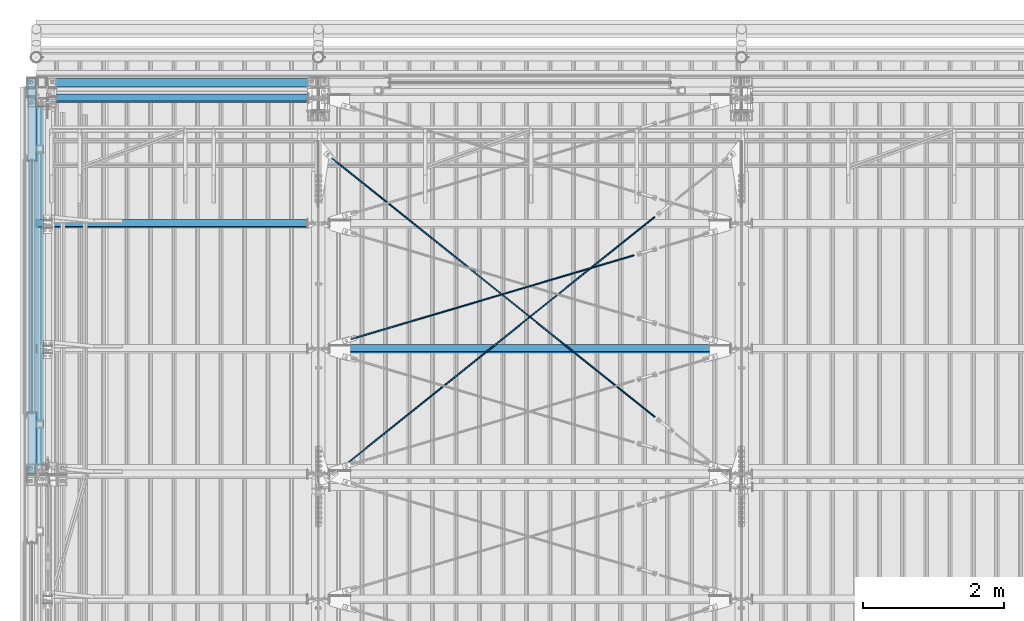
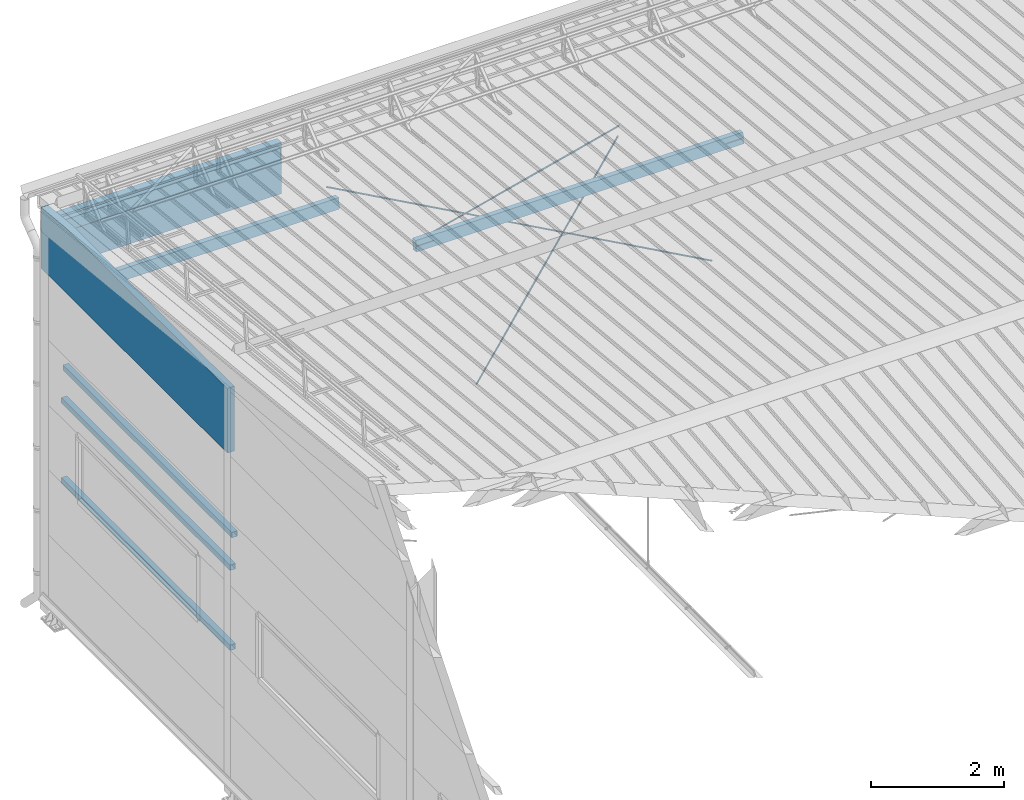
# One storey, part 264 of 709: 11 beams, 5 openings, 11 elements without a shape of their own.
"""IFC4 building model written with IfcOpenShell, lengths in millimetres."""

import ifcopenshell
import ifcopenshell.guid

model = None  # the IFC model being written
_history = None  # IfcOwnerHistory: only IFC2X3 demands one
_inside = {}  # id of a spatial element -> (the spatial element, [elements in it])
_under = {}  # id of a project, library or spatial element -> (it, [spatial elements below it])
_declared = {}  # id of a project -> (the project, [libraries it declares])
_typed = {}  # id of a type object -> (the type object, [elements of that type])
_made_of = {}  # id of a material, layer set ... -> (it, [elements and type objects made of it])


def new_model(schema):
    """Start an empty IFC model of exactly this schema.

    Asked for "IFC4X3", IfcOpenShell would pick the latest addendum, in which some entities
    have other attributes; the version numbers below select the first issue.
    IFC2X3 requires an IfcOwnerHistory on every rooted entity: one is made here for all.
    """
    global model, _history
    if schema == "IFC4X3":
        model = ifcopenshell.file(schema_version=(4, 3, 0, 0))
    else:
        model = ifcopenshell.file(schema=schema)
    _inside.clear()
    _under.clear()
    _declared.clear()
    _typed.clear()
    _made_of.clear()
    _history = None
    if model.schema == "IFC2X3":
        org = make("IfcOrganization", Name="unknown")
        user = make(
            "IfcPersonAndOrganization",
            ThePerson=make("IfcPerson", FamilyName="unknown"),
            TheOrganization=org,
        )
        app = make(
            "IfcApplication",
            ApplicationDeveloper=org,
            Version="unknown",
            ApplicationFullName="unknown",
            ApplicationIdentifier="unknown",
        )
        _history = make(
            "IfcOwnerHistory",
            OwningUser=user,
            OwningApplication=app,
            ChangeAction="ADDED",
            CreationDate=0,
        )
    return model


def make(cls, **values):
    """One entity of the class cls with the attributes given. An attribute that is None is left unset."""
    return model.create_entity(
        cls, **{name: value for name, value in values.items() if value is not None}
    )


def rooted(cls, **values):
    """An entity with a GlobalId (a new one), such as an element, a storey or a relation."""
    return make(cls, GlobalId=ifcopenshell.guid.new(), OwnerHistory=_history, **values)


def si_unit(unit_type, name, prefix=None):
    """IfcSIUnit, for example si_unit("LENGTHUNIT", "METRE", prefix="MILLI")."""
    return make("IfcSIUnit", UnitType=unit_type, Prefix=prefix, Name=name)


def assignment(units):
    """IfcUnitAssignment: the units of a project."""
    return None if units is None else make("IfcUnitAssignment", Units=units)


def point(xyz):
    """IfcCartesianPoint."""
    return None if xyz is None else make("IfcCartesianPoint", Coordinates=xyz)


def direction(xyz):
    """IfcDirection."""
    return None if xyz is None else make("IfcDirection", DirectionRatios=xyz)


def frame(location, z_axis=None, x_axis=None):
    """IfcAxis2Placement3D, a coordinate frame: its origin and axes. An axis left out is left unset."""
    return make(
        "IfcAxis2Placement3D",
        Location=point(location),
        Axis=direction(z_axis),
        RefDirection=direction(x_axis),
    )


def origin_with_axes():
    """The frame at (0, 0, 0) with the z axis (0, 0, 1) and the x axis (1, 0, 0) written out."""
    return frame((0.0, 0.0, 0.0), z_axis=(0.0, 0.0, 1.0), x_axis=(1.0, 0.0, 0.0))


def place(relative_to, where):
    """IfcLocalPlacement: puts the frame where relative to a parent placement (None: the world)."""
    return make(
        "IfcLocalPlacement", PlacementRelTo=relative_to, RelativePlacement=where
    )


def context(
    kind, dimensions, precision=None, world=None, true_north=None, identifier=None
):
    """IfcGeometricRepresentationContext, for example the 3D "Model" context."""
    return make(
        "IfcGeometricRepresentationContext",
        ContextIdentifier=identifier,
        ContextType=kind,
        CoordinateSpaceDimension=dimensions,
        Precision=precision,
        WorldCoordinateSystem=world,
        TrueNorth=true_north,
    )


def subcontext(parent, identifier, kind, view, scale=None):
    """IfcGeometricRepresentationSubContext, for example "Body" below "Model"."""
    return make(
        "IfcGeometricRepresentationSubContext",
        ContextIdentifier=identifier,
        ContextType=kind,
        ParentContext=parent,
        TargetScale=scale,
        TargetView=view,
    )


def project(units=None, contexts=None):
    """IfcProject with its units and contexts."""
    return rooted(
        "IfcProject",
        Name="project",
        RepresentationContexts=contexts,
        UnitsInContext=assignment(units),
    )


def spatial(cls, under=None, at=None, **own):
    """A site, building, storey or space (cls), placed at a placement, below another one or the project."""
    s = rooted(cls, ObjectPlacement=at, **own)
    if under is not None:
        _under.setdefault(under.id(), (under, []))[1].append(s)
    return s


def point_list(points):
    """IfcCartesianPointList2D or 3D."""
    cls = (
        "IfcCartesianPointList2D" if len(points[0]) == 2 else "IfcCartesianPointList3D"
    )
    return make(cls, CoordList=points)


def line(*indices):
    """IfcLineIndex: a straight run through numbered points of an indexed curve."""
    return model.create_entity("IfcLineIndex", indices)


def indexed_curve(points, segments=None, self_intersect=None):
    """IfcIndexedPolyCurve: lines and arcs through numbered points (the first is 1)."""
    return make(
        "IfcIndexedPolyCurve",
        Points=point_list(points),
        Segments=segments,
        SelfIntersect=self_intersect,
    )


def outline(outer, holes=None, kind="AREA"):
    """IfcArbitraryClosedProfileDef: a profile drawn as a closed curve; with holes, ...WithVoids."""
    if holes is None:
        return make("IfcArbitraryClosedProfileDef", ProfileType=kind, OuterCurve=outer)
    return make(
        "IfcArbitraryProfileDefWithVoids",
        ProfileType=kind,
        OuterCurve=outer,
        InnerCurves=holes,
    )


def extrude(swept, where, along, depth):
    """IfcExtrudedAreaSolid: the profile swept, set in the frame where, extruded along a direction by depth."""
    return make(
        "IfcExtrudedAreaSolid",
        SweptArea=swept,
        Position=where,
        ExtrudedDirection=direction(along),
        Depth=depth,
    )


def polygons(points, faces, closed=None, point_numbers=None):
    """IfcPolygonalFaceSet: a face is its outer loop, then its inner loops; points numbered from 1."""
    made = []
    for loops in faces:
        if len(loops) == 1:
            made.append(make("IfcIndexedPolygonalFace", CoordIndex=loops[0]))
        else:
            made.append(
                make(
                    "IfcIndexedPolygonalFaceWithVoids",
                    CoordIndex=loops[0],
                    InnerCoordIndices=loops[1:],
                )
            )
    return make(
        "IfcPolygonalFaceSet",
        Coordinates=point_list(points),
        Closed=closed,
        Faces=made,
        PnIndex=point_numbers,
    )


def shape(context_of_items, identifier, shape_type, items):
    """IfcShapeRepresentation: the items that make up one representation, for example the "Body"."""
    return make(
        "IfcShapeRepresentation",
        ContextOfItems=context_of_items,
        RepresentationIdentifier=identifier,
        RepresentationType=shape_type,
        Items=items,
    )


def material(Name=None, Category=None):
    """IfcMaterial."""
    return make("IfcMaterial", Name=Name, Category=Category)


def made_of(thing, what):
    """Note that an element or type object is made of a material, layer set ...; save() writes the relation."""
    if what is not None:
        _made_of.setdefault(what.id(), (what, []))[1].append(thing)
    return thing


def element(
    cls,
    number,
    at=None,
    inside=None,
    cuts=None,
    type_object=None,
    material=None,
    context=None,
    identifier="Body",
    shape_type=None,
    held_by="IfcProductDefinitionShape",
    body=None,
    shapes=None,
    **own,
):
    """One element of the class cls, such as IfcWall. Its Tag is "e" and its number.

    at: its placement. inside: the storey or other place that contains it. cuts: it is an
    opening in that element (IfcRelVoidsElement). A single representation is given by context,
    identifier, shape_type and body (its items); several are given by shapes. held_by: the class
    of the entity that holds the representations. save() writes the other relations.
    """
    e = rooted(cls, Tag="e%d" % number, ObjectPlacement=at, **own)
    if body is not None:
        shapes = [shape(context, identifier, shape_type, body)]
    if shapes is not None:
        e.Representation = make(held_by, Representations=shapes)
    if inside is not None:
        _inside.setdefault(inside.id(), (inside, []))[1].append(e)
    if cuts is not None:
        rooted(
            "IfcRelVoidsElement", RelatingBuildingElement=cuts, RelatedOpeningElement=e
        )
    if type_object is not None:
        _typed.setdefault(type_object.id(), (type_object, []))[1].append(e)
    return made_of(e, material)


def aggregate(whole, parts):
    """IfcRelAggregates: a whole, such as a stair, and the parts it consists of."""
    return rooted("IfcRelAggregates", RelatingObject=whole, RelatedObjects=parts)


def save(model, path):
    """Write the relations noted so far, then the file.

    IfcRelAggregates (storeys below a building ...), IfcRelContainedInSpatialStructure (elements
    in a storey), IfcRelDefinesByType, IfcRelAssociatesMaterial and IfcRelDeclares: one each for
    every whole, place, type object, material and project.
    """
    for whole, parts in _under.values():
        aggregate(whole, parts)
    for where, things in _inside.values():
        rooted(
            "IfcRelContainedInSpatialStructure",
            RelatedElements=things,
            RelatingStructure=where,
        )
    for kind, things in _typed.values():
        rooted("IfcRelDefinesByType", RelatedObjects=things, RelatingType=kind)
    for what, things in _made_of.values():
        rooted("IfcRelAssociatesMaterial", RelatedObjects=things, RelatingMaterial=what)
    for by, libraries in _declared.values():
        rooted("IfcRelDeclares", RelatingContext=by, RelatedDefinitions=libraries)
    model.write(path)


model = new_model("IFC4")

# Units and contexts
model_context = context("Model", 3, precision=0.2, world=origin_with_axes(), true_north=direction((0.0, 1.0)))
body_context = subcontext(model_context, "Body", "Model", "MODEL_VIEW")
reference_context = subcontext(model_context, "Reference", "Model", "MODEL_VIEW")
ifc_project = project(units=[si_unit("LENGTHUNIT", "METRE", prefix="MILLI"), si_unit("AREAUNIT", "SQUARE_METRE"), si_unit("VOLUMEUNIT", "CUBIC_METRE"), si_unit("MASSUNIT", "GRAM", prefix="KILO"), si_unit("TIMEUNIT", "SECOND"), si_unit("PLANEANGLEUNIT", "RADIAN"), si_unit("SOLIDANGLEUNIT", "STERADIAN"), si_unit("THERMODYNAMICTEMPERATUREUNIT", "DEGREE_CELSIUS"), si_unit("LUMINOUSINTENSITYUNIT", "LUMEN")], contexts=[model_context])

# Site, building, storey
site_placement = place(None, origin_with_axes())
site = spatial("IfcSite", under=ifc_project, at=site_placement, CompositionType="ELEMENT")
building_placement = place(site_placement, origin_with_axes())
building = spatial("IfcBuilding", under=site, at=building_placement, Name="Undefined", CompositionType="ELEMENT")
storey_placement = place(building_placement, origin_with_axes())
storey = spatial("IfcBuildingStorey", under=building, at=storey_placement, Name="Undefined", CompositionType="ELEMENT", Elevation=0.0)

# Assembly, beam, voiding feature
assembly_1_placement = place(storey_placement, frame((4000.0, 16334.90348, 5984.78262), z_axis=(0.625451877, -0.7802627439, 1e-10), x_axis=(0.7742288439, 0.6206151549, 0.124123031)))
assembly_1 = element("IfcElementAssembly", 1, at=assembly_1_placement, inside=storey)
ifc_material_1 = material(Name="C355-5", Category="STEEL")
beam_1_placement = place(assembly_1_placement, origin_with_axes())
beam_1 = element("IfcBeam", 2, at=beam_1_placement, material=ifc_material_1, ObjectType="480", context=body_context, shape_type="Tessellation", body=[
    polygons([(6339.64669, 7.36121, 4.25), (6339.64669, 6.01041, 6.0104), (6339.64669, 4.25, 7.36121), (6339.64669, 2.19996, 8.21037), (6339.64669, 0.0, 8.5), (6339.64669, -2.19996, 8.21037), (6339.64669, -4.25, 7.36121), (6339.64669, -6.01041, 6.0104), (6339.64669, -7.36122, 4.25), (6339.64669, -8.21037, 2.19996), (6339.64669, -8.5, 0.0), (6339.64669, -8.21037, -2.19996), (6339.64669, -7.36122, -4.25), (6339.64669, -6.01041, -6.01041), (6339.64669, -4.25, -7.36122), (6339.64669, -2.19996, -8.21037), (6339.64669, 0.0, -8.5), (6339.64669, 2.19996, -8.21037), (6339.64669, 4.25, -7.36122), (6339.64669, 6.01041, -6.01041), (6339.64669, 7.36121, -4.25), (6339.64669, 8.21037, -2.19996), (6339.64669, 8.5, 0.0), (6339.64669, 8.21037, 2.19996), (6159.64669, 8.21037, 2.19996), (6159.64669, 7.36121, 4.25), (6159.64669, 6.01041, 6.0104), (6159.64669, 4.25, 7.36121), (6159.64669, 2.19996, 8.21037), (6159.64669, 0.0, 8.5), (6159.64669, -2.19996, 8.21037), (6159.64669, -4.25, 7.36121), (6159.64669, -6.01041, 6.0104), (6159.64669, -7.36122, 4.25), (6159.64669, -8.21037, 2.19996), (6159.64669, -8.5, 0.0), (6159.64669, -8.21037, -2.19996), (6159.64669, -7.36122, -4.25), (6159.64669, -6.01041, -6.01041), (6159.64669, -4.25, -7.36122), (6159.64669, -2.19996, -8.21037), (6159.64669, 0.0, -8.5), (6159.64669, 2.19996, -8.21037), (6159.64669, 4.25, -7.36122), (6159.64669, 6.01041, -6.01041), (6159.64669, 7.36121, -4.25), (6159.64669, 8.21037, -2.19996), (6159.64669, 8.5, 0.0), (6159.64669, 10.0, 0.0), (6159.64669, 9.65926, 2.58819), (6159.64669, 8.66025, 5.0), (6159.64669, 7.07107, 7.07107), (6159.64669, 5.0, 8.66025), (6159.64669, 2.58819, 9.65926), (6159.64669, 0.0, 10.0), (6159.64669, -2.58819, 9.65926), (6159.64669, -5.0, 8.66025), (6159.64669, -7.07107, 7.07107), (6159.64669, -8.66025, 5.0), (6159.64669, -9.65926, 2.58819), (6159.64669, -10.0, 0.0), (6159.64669, -9.65926, -2.58819), (6159.64669, -8.66025, -5.0), (6159.64669, -7.07107, -7.07107), (6159.64669, -5.0, -8.66025), (6159.64669, -2.58819, -9.65926), (6159.64669, 0.0, -10.0), (6159.64669, 2.58819, -9.65926), (6159.64669, 5.0, -8.66025), (6159.64669, 7.07107, -7.07107), (6159.64669, 8.66025, -5.0), (6159.64669, 9.65926, -2.58819), (259.57474, 2.58819, 9.65926), (259.57474, 5.0, 8.66025), (259.57474, 7.07107, 7.07107), (259.57474, 8.66025, 5.0), (259.57474, 9.65926, 2.58819), (259.57474, 10.0, 0.0), (259.57474, 9.65926, -2.58819), (259.57474, 8.66025, -5.0), (259.57474, 7.07107, -7.07107), (259.57474, 5.0, -8.66025), (259.57474, 2.58819, -9.65926), (259.57474, 0.0, -10.0), (259.57474, -2.58819, -9.65926), (259.57474, -5.0, -8.66025), (259.57474, -7.07107, -7.07107), (259.57474, -8.66025, -5.0), (259.57474, -9.65926, -2.58819), (259.57474, -10.0, 0.0), (259.57474, -9.65926, 2.58819), (259.57474, -8.66025, 5.0), (259.57474, -7.07107, 7.07107), (259.57474, -5.0, 8.66025), (259.57474, -2.58819, 9.65926), (259.57474, 0.0, 10.0)], [[[1, 2, 3, 4, 5, 6, 7, 8, 9, 10, 11, 12, 13, 14, 15, 16, 17, 18, 19, 20, 21, 22, 23, 24]], [[24, 25, 26, 1]], [[1, 26, 27, 2]], [[2, 27, 28, 3]], [[3, 28, 29, 4]], [[4, 29, 30, 5]], [[5, 30, 31, 6]], [[6, 31, 32, 7]], [[7, 32, 33, 8]], [[8, 33, 34, 9]], [[9, 34, 35, 10]], [[10, 35, 36, 11]], [[11, 36, 37, 12]], [[12, 37, 38, 13]], [[13, 38, 39, 14]], [[14, 39, 40, 15]], [[15, 40, 41, 16]], [[16, 41, 42, 17]], [[17, 42, 43, 18]], [[18, 43, 44, 19]], [[19, 44, 45, 20]], [[20, 45, 46, 21]], [[21, 46, 47, 22]], [[22, 47, 48, 23]], [[23, 48, 25, 24]], [[49, 50, 51, 52, 53, 54, 55, 56, 57, 58, 59, 60, 61, 62, 63, 64, 65, 66, 67, 68, 69, 70, 71, 72], [47, 46, 45, 44, 43, 42, 41, 40, 39, 38, 37, 36, 35, 34, 33, 32, 31, 30, 29, 28, 27, 26, 25, 48]], [[73, 74, 75, 76, 77, 78, 79, 80, 81, 82, 83, 84, 85, 86, 87, 88, 89, 90, 91, 92, 93, 94, 95, 96]], [[79, 78, 49, 72]], [[80, 79, 72, 71]], [[81, 80, 71, 70]], [[82, 81, 70, 69]], [[83, 82, 69, 68]], [[84, 83, 68, 67]], [[85, 84, 67, 66]], [[86, 85, 66, 65]], [[87, 86, 65, 64]], [[88, 87, 64, 63]], [[89, 88, 63, 62]], [[90, 89, 62, 61]], [[91, 90, 61, 60]], [[92, 91, 60, 59]], [[93, 92, 59, 58]], [[94, 93, 58, 57]], [[95, 94, 57, 56]], [[96, 95, 56, 55]], [[73, 96, 55, 54]], [[74, 73, 54, 53]], [[75, 74, 53, 52]], [[76, 75, 52, 51]], [[77, 76, 51, 50]], [[78, 77, 50, 49]]], closed=True),
])
voiding_feature_1_placement = place(beam_1_placement, frame((6339.64669, 0.0, 0.0), z_axis=(0.0, 1.0, 0.0), x_axis=(-1.0, 0.0, 0.0)))
element("IfcVoidingFeature", 3, at=voiding_feature_1_placement, cuts=beam_1, PredefinedType="HOLE", context=reference_context, identifier="Reference", shape_type="SolidModel", body=[
    extrude(outline(indexed_curve([(10.5, 0.0), (10.14222, 2.7176), (9.09327, 5.25), (7.42462, 7.42462), (5.25, 9.09327), (2.7176, 10.14222), (0.0, 10.5), (-2.7176, 10.14222), (-5.25, 9.09327), (-7.42462, 7.42462), (-9.09327, 5.25), (-10.14222, 2.7176), (-10.5, 0.0), (-10.14222, -2.7176), (-9.09327, -5.25), (-7.42462, -7.42462), (-5.25, -9.09327), (-2.7176, -10.14222), (0.0, -10.5), (2.7176, -10.14222), (5.25, -9.09327), (7.42462, -7.42462), (9.09327, -5.25), (10.14222, -2.7176)], segments=[line(1, 2, 3, 4, 5, 6, 7, 8, 9, 10, 11, 12, 13, 14, 15, 16, 17, 18, 19, 20, 21, 22, 23, 24, 1)])), frame((0.0, 0.0, 0.0), z_axis=(-1.0, 0.0, 0.0), x_axis=(0.0, 0.0, 1.0)), (0.0, 0.0, -1.0), 180.0),
])
aggregate(assembly_1, [beam_1])

assembly_2_placement = place(storey_placement, frame((4000.0, 21144.45166, 6946.69226), z_axis=(-0.625451877, -0.7802627439, 1e-10), x_axis=(0.7742288439, -0.6206151549, -0.124123031)))
assembly_2 = element("IfcElementAssembly", 4, at=assembly_2_placement, inside=storey)
beam_2_placement = place(assembly_2_placement, origin_with_axes())
beam_2 = element("IfcBeam", 5, at=beam_2_placement, material=ifc_material_1, ObjectType="485", context=body_context, shape_type="Tessellation", body=[
    polygons([(6339.64669, 7.36122, 4.25), (6339.64669, 6.01041, 6.01041), (6339.64669, 4.25, 7.36122), (6339.64669, 2.19996, 8.21037), (6339.64669, 0.0, 8.5), (6339.64669, -2.19996, 8.21037), (6339.64669, -4.25, 7.36122), (6339.64669, -6.01041, 6.01041), (6339.64669, -7.36121, 4.25), (6339.64669, -8.21037, 2.19996), (6339.64669, -8.5, 0.0), (6339.64669, -8.21037, -2.19996), (6339.64669, -7.36121, -4.25), (6339.64669, -6.01041, -6.0104), (6339.64669, -4.25, -7.36121), (6339.64669, -2.19996, -8.21037), (6339.64669, 0.0, -8.5), (6339.64669, 2.19996, -8.21037), (6339.64669, 4.25, -7.36121), (6339.64669, 6.01041, -6.0104), (6339.64669, 7.36122, -4.25), (6339.64669, 8.21037, -2.19996), (6339.64669, 8.5, 0.0), (6339.64669, 8.21037, 2.19996), (6159.64669, 8.21037, 2.19996), (6159.64669, 7.36122, 4.25), (6159.64669, 6.01041, 6.01041), (6159.64669, 4.25, 7.36122), (6159.64669, 2.19996, 8.21037), (6159.64669, 0.0, 8.5), (6159.64669, -2.19996, 8.21037), (6159.64669, -4.25, 7.36122), (6159.64669, -6.01041, 6.01041), (6159.64669, -7.36121, 4.25), (6159.64669, -8.21037, 2.19996), (6159.64669, -8.5, 0.0), (6159.64669, -8.21037, -2.19996), (6159.64669, -7.36121, -4.25), (6159.64669, -6.01041, -6.0104), (6159.64669, -4.25, -7.36121), (6159.64669, -2.19996, -8.21037), (6159.64669, 0.0, -8.5), (6159.64669, 2.19996, -8.21037), (6159.64669, 4.25, -7.36121), (6159.64669, 6.01041, -6.0104), (6159.64669, 7.36122, -4.25), (6159.64669, 8.21037, -2.19996), (6159.64669, 8.5, 0.0), (6159.64669, 10.0, 0.0), (6159.64669, 9.65926, 2.58819), (6159.64669, 8.66025, 5.0), (6159.64669, 7.07107, 7.07107), (6159.64669, 5.0, 8.66025), (6159.64669, 2.58819, 9.65926), (6159.64669, 0.0, 10.0), (6159.64669, -2.58819, 9.65926), (6159.64669, -5.0, 8.66025), (6159.64669, -7.07107, 7.07107), (6159.64669, -8.66025, 5.0), (6159.64669, -9.65926, 2.58819), (6159.64669, -10.0, 0.0), (6159.64669, -9.65926, -2.58819), (6159.64669, -8.66025, -5.0), (6159.64669, -7.07107, -7.07107), (6159.64669, -5.0, -8.66025), (6159.64669, -2.58819, -9.65926), (6159.64669, 0.0, -10.0), (6159.64669, 2.58819, -9.65926), (6159.64669, 5.0, -8.66025), (6159.64669, 7.07107, -7.07107), (6159.64669, 8.66025, -5.0), (6159.64669, 9.65926, -2.58819), (246.65866, 2.58819, 9.65926), (246.65866, 5.0, 8.66025), (246.65866, 7.07107, 7.07107), (246.65866, 8.66025, 5.0), (246.65866, 9.65926, 2.58819), (246.65866, 10.0, 0.0), (246.65866, 9.65926, -2.58819), (246.65866, 8.66025, -5.0), (246.65866, 7.07107, -7.07107), (246.65866, 5.0, -8.66025), (246.65866, 2.58819, -9.65926), (246.65866, 0.0, -10.0), (246.65866, -2.58819, -9.65926), (246.65866, -5.0, -8.66025), (246.65866, -7.07107, -7.07107), (246.65866, -8.66025, -5.0), (246.65866, -9.65926, -2.58819), (246.65866, -10.0, 0.0), (246.65866, -9.65926, 2.58819), (246.65866, -8.66025, 5.0), (246.65866, -7.07107, 7.07107), (246.65866, -5.0, 8.66025), (246.65866, -2.58819, 9.65926), (246.65866, 0.0, 10.0)], [[[1, 2, 3, 4, 5, 6, 7, 8, 9, 10, 11, 12, 13, 14, 15, 16, 17, 18, 19, 20, 21, 22, 23, 24]], [[24, 25, 26, 1]], [[1, 26, 27, 2]], [[2, 27, 28, 3]], [[3, 28, 29, 4]], [[4, 29, 30, 5]], [[5, 30, 31, 6]], [[6, 31, 32, 7]], [[7, 32, 33, 8]], [[8, 33, 34, 9]], [[9, 34, 35, 10]], [[10, 35, 36, 11]], [[11, 36, 37, 12]], [[12, 37, 38, 13]], [[13, 38, 39, 14]], [[14, 39, 40, 15]], [[15, 40, 41, 16]], [[16, 41, 42, 17]], [[17, 42, 43, 18]], [[18, 43, 44, 19]], [[19, 44, 45, 20]], [[20, 45, 46, 21]], [[21, 46, 47, 22]], [[22, 47, 48, 23]], [[23, 48, 25, 24]], [[49, 50, 51, 52, 53, 54, 55, 56, 57, 58, 59, 60, 61, 62, 63, 64, 65, 66, 67, 68, 69, 70, 71, 72], [47, 46, 45, 44, 43, 42, 41, 40, 39, 38, 37, 36, 35, 34, 33, 32, 31, 30, 29, 28, 27, 26, 25, 48]], [[73, 74, 75, 76, 77, 78, 79, 80, 81, 82, 83, 84, 85, 86, 87, 88, 89, 90, 91, 92, 93, 94, 95, 96]], [[79, 78, 49, 72]], [[80, 79, 72, 71]], [[81, 80, 71, 70]], [[82, 81, 70, 69]], [[83, 82, 69, 68]], [[84, 83, 68, 67]], [[85, 84, 67, 66]], [[86, 85, 66, 65]], [[87, 86, 65, 64]], [[88, 87, 64, 63]], [[89, 88, 63, 62]], [[90, 89, 62, 61]], [[91, 90, 61, 60]], [[92, 91, 60, 59]], [[93, 92, 59, 58]], [[94, 93, 58, 57]], [[95, 94, 57, 56]], [[96, 95, 56, 55]], [[73, 96, 55, 54]], [[74, 73, 54, 53]], [[75, 74, 53, 52]], [[76, 75, 52, 51]], [[77, 76, 51, 50]], [[78, 77, 50, 49]]], closed=True),
])
voiding_feature_2_placement = place(beam_2_placement, frame((6339.64669, 0.0, 0.0), z_axis=(0.0, 1.0, 0.0), x_axis=(-1.0, 0.0, 0.0)))
element("IfcVoidingFeature", 6, at=voiding_feature_2_placement, cuts=beam_2, PredefinedType="HOLE", context=reference_context, identifier="Reference", shape_type="SolidModel", body=[
    extrude(outline(indexed_curve([(10.5, 0.0), (10.14222, 2.7176), (9.09327, 5.25), (7.42462, 7.42462), (5.25, 9.09327), (2.7176, 10.14222), (0.0, 10.5), (-2.7176, 10.14222), (-5.25, 9.09327), (-7.42462, 7.42462), (-9.09327, 5.25), (-10.14222, 2.7176), (-10.5, 0.0), (-10.14222, -2.7176), (-9.09327, -5.25), (-7.42462, -7.42462), (-5.25, -9.09327), (-2.7176, -10.14222), (0.0, -10.5), (2.7176, -10.14222), (5.25, -9.09327), (7.42462, -7.42462), (9.09327, -5.25), (10.14222, -2.7176)], segments=[line(1, 2, 3, 4, 5, 6, 7, 8, 9, 10, 11, 12, 13, 14, 15, 16, 17, 18, 19, 20, 21, 22, 23, 24, 1)])), frame((0.0, 0.0, 0.0), z_axis=(-1.0, 0.0, 0.0), x_axis=(0.0, 0.0, 1.0)), (0.0, 0.0, -1.0), 180.0),
])
aggregate(assembly_2, [beam_2])

# Assembly, beam
assembly_3_placement = place(storey_placement, frame((50.0, 21920.0, 2550.0), z_axis=(0.0, 0.0, -1.0), x_axis=(0.0, -1.0, 0.0)))
assembly_3 = element("IfcElementAssembly", 7, at=assembly_3_placement, inside=storey)
ifc_material_2 = material(Name="C355", Category="STEEL")
beam_3_placement = place(assembly_3_placement, origin_with_axes())
beam_3 = element("IfcBeam", 8, at=beam_3_placement, material=ifc_material_2, ObjectType="492", context=body_context, shape_type="Tessellation", body=[
    polygons([(5277.5, 50.0, 50.0), (5277.5, 50.0, -50.0), (198.0, 50.0, -50.0), (198.0, 50.0, 50.0), (5277.5, -50.0, 50.0), (198.0, -50.0, 50.0), (5277.5, -50.0, -50.0), (198.0, -50.0, -50.0), (5277.5, 47.0, -47.0), (5277.5, 47.0, 47.0), (198.0, 47.0, 47.0), (198.0, 47.0, -47.0), (5277.5, -47.0, -47.0), (198.0, -47.0, -47.0), (5277.5, -47.0, 47.0), (198.0, -47.0, 47.0)], [[[1, 2, 3, 4]], [[5, 1, 4, 6]], [[7, 5, 6, 8]], [[2, 7, 8, 3]], [[1, 5, 7, 2], [10, 9, 13, 15]], [[9, 10, 11, 12]], [[13, 9, 12, 14]], [[15, 13, 14, 16]], [[10, 15, 16, 11]], [[8, 6, 4, 3], [14, 12, 11, 16]]], closed=True),
])
aggregate(assembly_3, [beam_3])

assembly_4_placement = place(storey_placement, frame((50.0, 21920.0, 4020.0), z_axis=(0.0, 0.0, -1.0), x_axis=(0.0, -1.0, 0.0)))
assembly_4 = element("IfcElementAssembly", 9, at=assembly_4_placement, inside=storey)
beam_4_placement = place(assembly_4_placement, origin_with_axes())
beam_4 = element("IfcBeam", 10, at=beam_4_placement, material=ifc_material_2, ObjectType="492", context=body_context, shape_type="Tessellation", body=[
    polygons([(5277.5, 50.0, 50.0), (5277.5, 50.0, -50.0), (198.0, 50.0, -50.0), (198.0, 50.0, 50.0), (5277.5, -50.0, 50.0), (198.0, -50.0, 50.0), (5277.5, -50.0, -50.0), (198.0, -50.0, -50.0), (5277.5, 47.0, -47.0), (5277.5, 47.0, 47.0), (198.0, 47.0, 47.0), (198.0, 47.0, -47.0), (5277.5, -47.0, -47.0), (198.0, -47.0, -47.0), (5277.5, -47.0, 47.0), (198.0, -47.0, 47.0)], [[[1, 2, 3, 4]], [[5, 1, 4, 6]], [[7, 5, 6, 8]], [[2, 7, 8, 3]], [[1, 5, 7, 2], [10, 9, 13, 15]], [[9, 10, 11, 12]], [[13, 9, 12, 14]], [[15, 13, 14, 16]], [[10, 15, 16, 11]], [[8, 6, 4, 3], [14, 12, 11, 16]]], closed=True),
])
aggregate(assembly_4, [beam_4])

assembly_5_placement = place(storey_placement, frame((80.0, 21920.0, 4610.0), z_axis=(0.0, 0.0, -1.0), x_axis=(0.0, -1.0, 0.0)))
assembly_5 = element("IfcElementAssembly", 11, at=assembly_5_placement, inside=storey)
beam_5_placement = place(assembly_5_placement, origin_with_axes())
beam_5 = element("IfcBeam", 12, at=beam_5_placement, material=ifc_material_2, ObjectType="494", context=body_context, shape_type="Tessellation", body=[
    polygons([(5277.5, 50.0, 50.0), (5277.5, 50.0, -50.0), (198.0, 50.0, -50.0), (198.0, 50.0, 50.0), (5277.5, -50.0, 50.0), (198.0, -50.0, 50.0), (5277.5, -50.0, -50.0), (198.0, -50.0, -50.0), (5277.5, 47.0, -47.0), (5277.5, 47.0, 47.0), (198.0, 47.0, 47.0), (198.0, 47.0, -47.0), (5277.5, -47.0, -47.0), (198.0, -47.0, -47.0), (5277.5, -47.0, 47.0), (198.0, -47.0, 47.0)], [[[1, 2, 3, 4]], [[5, 1, 4, 6]], [[7, 5, 6, 8]], [[2, 7, 8, 3]], [[1, 5, 7, 2], [10, 9, 13, 15]], [[9, 10, 11, 12]], [[13, 9, 12, 14]], [[15, 13, 14, 16]], [[10, 15, 16, 11]], [[8, 6, 4, 3], [14, 12, 11, 16]]], closed=True),
])
aggregate(assembly_5, [beam_5])

# Assembly, beam, voiding feature
assembly_6_placement = place(storey_placement, frame((4000.0, 18287.44615, 7507.7594), z_axis=(0.2852311229, -0.9537021177, 0.0953702118), x_axis=(0.9584587662, 0.2838155751, -0.028381558)))
assembly_6 = element("IfcElementAssembly", 13, at=assembly_6_placement, inside=storey)
beam_6_placement = place(assembly_6_placement, origin_with_axes())
beam_6 = element("IfcBeam", 14, at=beam_6_placement, material=ifc_material_1, ObjectType="570", context=body_context, shape_type="Tessellation", body=[
    polygons([(4850.05021, 7.36122, 4.25), (4850.05021, 6.01041, 6.01041), (4850.05021, 4.25, 7.36121), (4850.05021, 2.19996, 8.21037), (4850.05021, 0.0, 8.5), (4850.05021, -2.19996, 8.21037), (4850.05021, -4.25, 7.36121), (4850.05021, -6.01041, 6.01041), (4850.05021, -7.36121, 4.25), (4850.05021, -8.21037, 2.19996), (4850.05021, -8.5, 0.0), (4850.05021, -8.21037, -2.19996), (4850.05021, -7.36121, -4.25), (4850.05021, -6.01041, -6.01041), (4850.05021, -4.25, -7.36122), (4850.05021, -2.19996, -8.21037), (4850.05021, 0.0, -8.5), (4850.05021, 2.19996, -8.21037), (4850.05021, 4.25, -7.36122), (4850.05021, 6.01041, -6.01041), (4850.05021, 7.36122, -4.25), (4850.05021, 8.21037, -2.19996), (4850.05021, 8.5, 0.0), (4850.05021, 8.21037, 2.19996), (4670.05021, 8.21037, 2.19996), (4670.05021, 7.36122, 4.25), (4670.05021, 6.01041, 6.01041), (4670.05021, 4.25, 7.36121), (4670.05021, 2.19996, 8.21037), (4670.05021, 0.0, 8.5), (4670.05021, -2.19996, 8.21037), (4670.05021, -4.25, 7.36121), (4670.05021, -6.01041, 6.01041), (4670.05021, -7.36121, 4.25), (4670.05021, -8.21037, 2.19996), (4670.05021, -8.5, 0.0), (4670.05021, -8.21037, -2.19996), (4670.05021, -7.36121, -4.25), (4670.05021, -6.01041, -6.01041), (4670.05021, -4.25, -7.36122), (4670.05021, -2.19996, -8.21037), (4670.05021, 0.0, -8.5), (4670.05021, 2.19996, -8.21037), (4670.05021, 4.25, -7.36122), (4670.05021, 6.01041, -6.01041), (4670.05021, 7.36122, -4.25), (4670.05021, 8.21037, -2.19996), (4670.05021, 8.5, 0.0), (4670.05021, 10.0, 0.0), (4670.05021, 9.65926, 2.58819), (4670.05021, 8.66025, 5.0), (4670.05021, 7.07107, 7.07107), (4670.05021, 5.0, 8.66025), (4670.05021, 2.58819, 9.65926), (4670.05021, 0.0, 10.0), (4670.05021, -2.58819, 9.65926), (4670.05021, -5.0, 8.66025), (4670.05021, -7.07107, 7.07107), (4670.05021, -8.66025, 5.0), (4670.05021, -9.65926, 2.58819), (4670.05021, -10.0, 0.0), (4670.05021, -9.65926, -2.58819), (4670.05021, -8.66025, -5.0), (4670.05021, -7.07107, -7.07107), (4670.05021, -5.0, -8.66025), (4670.05021, -2.58819, -9.65926), (4670.05021, 0.0, -10.0), (4670.05021, 2.58819, -9.65926), (4670.05021, 5.0, -8.66025), (4670.05021, 7.07107, -7.07107), (4670.05021, 8.66025, -5.0), (4670.05021, 9.65926, -2.58819), (483.0251, 2.58819, 9.65926), (483.0251, 5.0, 8.66025), (483.0251, 7.07107, 7.07107), (483.0251, 8.66025, 5.0), (483.0251, 9.65926, 2.58819), (483.0251, 10.0, 0.0), (483.0251, 9.65926, -2.58819), (483.0251, 8.66025, -5.0), (483.0251, 7.07107, -7.07107), (483.0251, 5.0, -8.66025), (483.0251, 2.58819, -9.65926), (483.0251, 0.0, -10.0), (483.0251, -2.58819, -9.65926), (483.0251, -5.0, -8.66025), (483.0251, -7.07107, -7.07107), (483.0251, -8.66025, -5.0), (483.0251, -9.65926, -2.58819), (483.0251, -10.0, 0.0), (483.0251, -9.65926, 2.58819), (483.0251, -8.66025, 5.0), (483.0251, -7.07107, 7.07107), (483.0251, -5.0, 8.66025), (483.0251, -2.58819, 9.65926), (483.0251, 0.0, 10.0)], [[[1, 2, 3, 4, 5, 6, 7, 8, 9, 10, 11, 12, 13, 14, 15, 16, 17, 18, 19, 20, 21, 22, 23, 24]], [[24, 25, 26, 1]], [[1, 26, 27, 2]], [[2, 27, 28, 3]], [[3, 28, 29, 4]], [[4, 29, 30, 5]], [[5, 30, 31, 6]], [[6, 31, 32, 7]], [[7, 32, 33, 8]], [[8, 33, 34, 9]], [[9, 34, 35, 10]], [[10, 35, 36, 11]], [[11, 36, 37, 12]], [[12, 37, 38, 13]], [[13, 38, 39, 14]], [[14, 39, 40, 15]], [[15, 40, 41, 16]], [[16, 41, 42, 17]], [[17, 42, 43, 18]], [[18, 43, 44, 19]], [[19, 44, 45, 20]], [[20, 45, 46, 21]], [[21, 46, 47, 22]], [[22, 47, 48, 23]], [[23, 48, 25, 24]], [[49, 50, 51, 52, 53, 54, 55, 56, 57, 58, 59, 60, 61, 62, 63, 64, 65, 66, 67, 68, 69, 70, 71, 72], [47, 46, 45, 44, 43, 42, 41, 40, 39, 38, 37, 36, 35, 34, 33, 32, 31, 30, 29, 28, 27, 26, 25, 48]], [[73, 74, 75, 76, 77, 78, 79, 80, 81, 82, 83, 84, 85, 86, 87, 88, 89, 90, 91, 92, 93, 94, 95, 96]], [[79, 78, 49, 72]], [[80, 79, 72, 71]], [[81, 80, 71, 70]], [[82, 81, 70, 69]], [[83, 82, 69, 68]], [[84, 83, 68, 67]], [[85, 84, 67, 66]], [[86, 85, 66, 65]], [[87, 86, 65, 64]], [[88, 87, 64, 63]], [[89, 88, 63, 62]], [[90, 89, 62, 61]], [[91, 90, 61, 60]], [[92, 91, 60, 59]], [[93, 92, 59, 58]], [[94, 93, 58, 57]], [[95, 94, 57, 56]], [[96, 95, 56, 55]], [[73, 96, 55, 54]], [[74, 73, 54, 53]], [[75, 74, 53, 52]], [[76, 75, 52, 51]], [[77, 76, 51, 50]], [[78, 77, 50, 49]]], closed=True),
])
voiding_feature_3_placement = place(beam_6_placement, frame((4850.05021, 0.0, 0.0), z_axis=(0.0, 1.0, 0.0), x_axis=(-1.0, 0.0, 0.0)))
element("IfcVoidingFeature", 15, at=voiding_feature_3_placement, cuts=beam_6, PredefinedType="HOLE", context=reference_context, identifier="Reference", shape_type="SolidModel", body=[
    extrude(outline(indexed_curve([(10.5, 0.0), (10.14222, 2.7176), (9.09327, 5.25), (7.42462, 7.42462), (5.25, 9.09327), (2.7176, 10.14222), (0.0, 10.5), (-2.7176, 10.14222), (-5.25, 9.09327), (-7.42462, 7.42462), (-9.09327, 5.25), (-10.14222, 2.7176), (-10.5, 0.0), (-10.14222, -2.7176), (-9.09327, -5.25), (-7.42462, -7.42462), (-5.25, -9.09327), (-2.7176, -10.14222), (0.0, -10.5), (2.7176, -10.14222), (5.25, -9.09327), (7.42462, -7.42462), (9.09327, -5.25), (10.14222, -2.7176)], segments=[line(1, 2, 3, 4, 5, 6, 7, 8, 9, 10, 11, 12, 13, 14, 15, 16, 17, 18, 19, 20, 21, 22, 23, 24, 1)])), frame((0.0, 0.0, 0.0), z_axis=(-1.0, 0.0, 0.0), x_axis=(0.0, 0.0, 1.0)), (0.0, 0.0, -1.0), 180.0),
])
aggregate(assembly_6, [beam_6])

# Assembly, beam
assembly_7_placement = place(storey_placement, frame((4000.0, 20063.34988, 7322.08923), z_axis=(0.0, -0.9950371902, 0.099503719), x_axis=(-1.0, 0.0, 0.0)))
assembly_7 = element("IfcElementAssembly", 16, at=assembly_7_placement, inside=storey)
beam_7_placement = place(assembly_7_placement, origin_with_axes())
beam_7 = element("IfcBeam", 17, at=beam_7_placement, material=ifc_material_2, ObjectType="563", context=body_context, shape_type="Tessellation", body=[
    polygons([(155.0, -100.0, 50.0), (155.0, -100.0, -50.0), (3992.0, -100.0, -50.0), (3992.0, -100.0, 50.0), (155.0, 100.0, 50.0), (3992.0, 100.0, 50.0), (155.0, 100.0, -50.0), (3992.0, 100.0, -50.0), (155.0, -96.0, 46.0), (155.0, 96.0, 46.0), (3992.0, 96.0, 46.0), (3992.0, -96.0, 46.0), (155.0, -96.0, -46.0), (3992.0, -96.0, -46.0), (155.0, 96.0, -46.0), (3992.0, 96.0, -46.0)], [[[1, 2, 3, 4]], [[5, 1, 4, 6]], [[7, 5, 6, 8]], [[2, 7, 8, 3]], [[1, 5, 7, 2], [15, 10, 9, 13]], [[9, 10, 11, 12]], [[13, 9, 12, 14]], [[15, 13, 14, 16]], [[10, 15, 16, 11]], [[3, 8, 6, 4], [14, 12, 11, 16]]], closed=True),
])
aggregate(assembly_7, [beam_7])

assembly_8_placement = place(storey_placement, frame((4000.0, 21840.04963, 7144.41925), z_axis=(0.0, -0.9950371902, 0.099503719), x_axis=(-1.0, 0.0, 0.0)))
assembly_8 = element("IfcElementAssembly", 18, at=assembly_8_placement, inside=storey)
beam_8_placement = place(assembly_8_placement, origin_with_axes())
beam_8 = element("IfcBeam", 19, at=beam_8_placement, material=ifc_material_2, ObjectType="562", context=body_context, shape_type="Tessellation", body=[
    polygons([(145.0, -100.0, 50.0), (145.0, -100.0, -50.0), (3972.0, -100.0, -50.0), (3972.0, -100.0, 50.0), (145.0, 100.0, 50.0), (3972.0, 100.0, 50.0), (145.0, 100.0, -50.0), (3972.0, 100.0, -50.0), (145.0, -96.0, 46.0), (145.0, 96.0, 46.0), (3972.0, 96.0, 46.0), (3972.0, -96.0, 46.0), (145.0, -96.0, -46.0), (3972.0, -96.0, -46.0), (145.0, 96.0, -46.0), (3972.0, 96.0, -46.0)], [[[1, 2, 3, 4]], [[5, 1, 4, 6]], [[7, 5, 6, 8]], [[2, 7, 8, 3]], [[1, 5, 7, 2], [15, 10, 9, 13]], [[9, 10, 11, 12]], [[13, 9, 12, 14]], [[15, 13, 14, 16]], [[10, 15, 16, 11]], [[3, 8, 6, 4], [14, 12, 11, 16]]], closed=True),
])
aggregate(assembly_8, [beam_8])

# Assembly, beam, voiding features
assembly_9_placement = place(storey_placement, frame((10000.0, 18286.65012, 7499.7991), z_axis=(0.0, -0.9950371902, 0.099503719), x_axis=(-1.0, 0.0, 0.0)))
assembly_9 = element("IfcElementAssembly", 20, at=assembly_9_placement, inside=storey)
beam_9_placement = place(assembly_9_placement, origin_with_axes())
beam_9 = element("IfcBeam", 21, at=beam_9_placement, material=ifc_material_2, ObjectType="566", context=body_context, shape_type="Tessellation", body=[
    polygons([(456.62586, -5.0, 50.0), (456.62586, -5.0, 46.0), (155.0, -5.0, 46.0), (155.0, -5.0, 50.0), (456.62586, 5.0, 50.0), (456.62586, 5.0, 46.0), (155.0, 5.0, 50.0), (155.0, 5.0, 46.0), (456.62586, -5.0, -46.0), (456.62586, -5.0, -50.0), (155.0, -5.0, -50.0), (155.0, -5.0, -46.0), (456.62586, 5.0, -46.0), (456.62586, 5.0, -50.0), (155.0, 5.0, -46.0), (155.0, 5.0, -50.0), (155.0, 96.0, 46.0), (155.0, 96.0, -46.0), (5845.0, 96.0, -46.0), (5845.0, 96.0, 46.0), (155.0, 100.0, -50.0), (5845.0, 100.0, -50.0), (5845.0, 5.0, -50.0), (5543.37413, 5.0, -50.0), (5543.37413, -5.0, -50.0), (5845.0, -5.0, -50.0), (5845.0, -100.0, -50.0), (155.0, -100.0, -50.0), (5845.00055, 5.0, -46.0), (5543.37413, 5.0, -46.0), (5543.37413, -5.0, -46.0), (5845.0, -5.0, -46.0), (155.0, -96.0, -46.0), (155.0, -96.0, 46.0), (5845.0, -96.0, 46.0), (5845.0, -96.0, -46.0), (5543.37413, -5.0, 50.0), (5543.37413, -5.0, 46.0), (5543.37413, 5.0, 46.0), (5543.37413, 5.0, 50.0), (5845.0, -5.0, 50.0), (5845.0, -5.0, 46.0), (5845.0, -100.0, 50.0), (155.0, -100.0, 50.0), (5845.0, 5.0, 46.0), (5845.00055, 5.0, 50.0), (5845.0, 100.0, 50.0), (155.0, 100.0, 50.0)], [[[1, 2, 3, 4]], [[5, 6, 2, 1]], [[7, 8, 6, 5]], [[9, 10, 11, 12]], [[13, 14, 10, 9]], [[15, 16, 14, 13]], [[17, 18, 19, 20]], [[21, 22, 23, 24, 25, 26, 27, 28, 11, 10, 14, 16]], [[29, 30, 24, 23]], [[31, 25, 24, 30]], [[32, 26, 25, 31]], [[33, 34, 35, 36]], [[37, 38, 39, 40]], [[41, 42, 38, 37]], [[43, 27, 26, 32, 36, 35, 42, 41]], [[44, 28, 27, 43]], [[34, 33, 12, 11, 28, 44, 4, 3]], [[17, 20, 45, 39, 38, 42, 35, 34, 3, 2, 6, 8]], [[46, 40, 39, 45]], [[20, 19, 29, 23, 22, 47, 46, 45]], [[21, 48, 47, 22]], [[4, 44, 43, 41, 37, 40, 46, 47, 48, 7, 5, 1]], [[48, 21, 16, 15, 18, 17, 8, 7]], [[12, 33, 36, 32, 31, 30, 29, 19, 18, 15, 13, 9]]], closed=True),
])
voiding_feature_4_placement = place(beam_9_placement, frame((5845.00055, 0.0, -93.07721), z_axis=(0.0, -1.0, 0.0), x_axis=(0.0, 0.0, 1.0)))
element("IfcVoidingFeature", 22, at=voiding_feature_4_placement, cuts=beam_9, Name="PLATE", PredefinedType="HOLE", context=reference_context, identifier="Reference", shape_type="SolidModel", body=[
    extrude(outline(indexed_curve([(0.0, 0.0), (186.15442, 0.0), (268.27702, 275.95562), (182.01573, 301.62642), (4.13868, 301.62642), (-82.1226, 275.95562)], segments=[line(1, 2, 3, 4, 5, 6, 1)])), frame((0.0, 0.0, 5.0), z_axis=(0.0, 0.0, 1.0), x_axis=(1.0, 0.0, 0.0)), (0.0, 0.0, -1.0), 10.0),
])
voiding_feature_5_placement = place(beam_9_placement, frame((154.99945, 0.0, 93.07721), z_axis=(0.0, -1.0, 0.0), x_axis=(0.0, 0.0, -1.0)))
element("IfcVoidingFeature", 23, at=voiding_feature_5_placement, cuts=beam_9, Name="PLATE", PredefinedType="HOLE", context=reference_context, identifier="Reference", shape_type="SolidModel", body=[
    extrude(outline(indexed_curve([(0.0, 0.0), (186.15442, 0.0), (268.27702, 275.95562), (182.01573, 301.62642), (4.13868, 301.62642), (-82.1226, 275.95562)], segments=[line(1, 2, 3, 4, 5, 6, 1)])), frame((0.0, 0.0, 5.0), z_axis=(0.0, 0.0, 1.0), x_axis=(1.0, 0.0, 0.0)), (0.0, 0.0, -1.0), 10.0),
])
aggregate(assembly_9, [beam_9])

# Assembly, beam
assembly_10_placement = place(storey_placement, frame((10.0, 22060.0, 6845.0), z_axis=(0.0, 0.0, -1.0), x_axis=(1.0, 0.0, 0.0)))
assembly_10 = element("IfcElementAssembly", 24, at=assembly_10_placement, inside=storey)
ifc_material_3 = material(Name="Insulation", Category="Insulation")
beam_10_placement = place(assembly_10_placement, origin_with_axes())
beam_10 = element("IfcBeam", 25, at=beam_10_placement, material=ifc_material_3, ObjectType="P-119", context=body_context, shape_type="Tessellation", body=[
    polygons([(0.0, 60.0, 595.0), (0.0, -60.0, 595.0), (3980.0, -60.0, 595.0), (3980.0, 60.0, 595.0), (3980.0, 60.0, -351.923), (0.0, 60.0, -351.923), (0.0, -60.0, -351.923), (3980.0, -60.0, -351.923)], [[[1, 2, 3, 4]], [[1, 4, 5, 6]], [[2, 1, 6, 7]], [[3, 2, 7, 8]], [[4, 3, 8, 5]], [[7, 6, 5, 8]]], closed=True),
])
aggregate(assembly_10, [beam_10])

assembly_11_placement = place(storey_placement, frame((-60.0, 16510.0, 6845.0), z_axis=(0.0, 0.0, -1.0), x_axis=(0.0, 1.0, 0.0)))
assembly_11 = element("IfcElementAssembly", 26, at=assembly_11_placement, inside=storey)
beam_11_placement = place(assembly_11_placement, origin_with_axes())
beam_11 = element("IfcBeam", 27, at=beam_11_placement, material=ifc_material_3, ObjectType="P-131", context=body_context, shape_type="Tessellation", body=[
    polygons([(0.0, -60.0, 595.0), (0.0, 60.0, 595.0), (0.0, 60.0, -595.0), (0.0, -60.0, -595.0), (5610.0, -60.0, 595.0), (5610.0, 60.0, 595.0), (5610.0, 60.0, -522.671), (4886.71, 60.0, -595.0), (4886.71, -60.0, -595.0), (5610.0, -60.0, -522.671)], [[[1, 2, 3, 4]], [[2, 1, 5, 6]], [[3, 2, 6, 7, 8]], [[4, 3, 8, 9]], [[5, 1, 4, 9, 10]], [[6, 5, 10, 7]], [[9, 8, 7, 10]]], closed=True),
])
aggregate(assembly_11, [beam_11])

save(model, "model.ifc")
